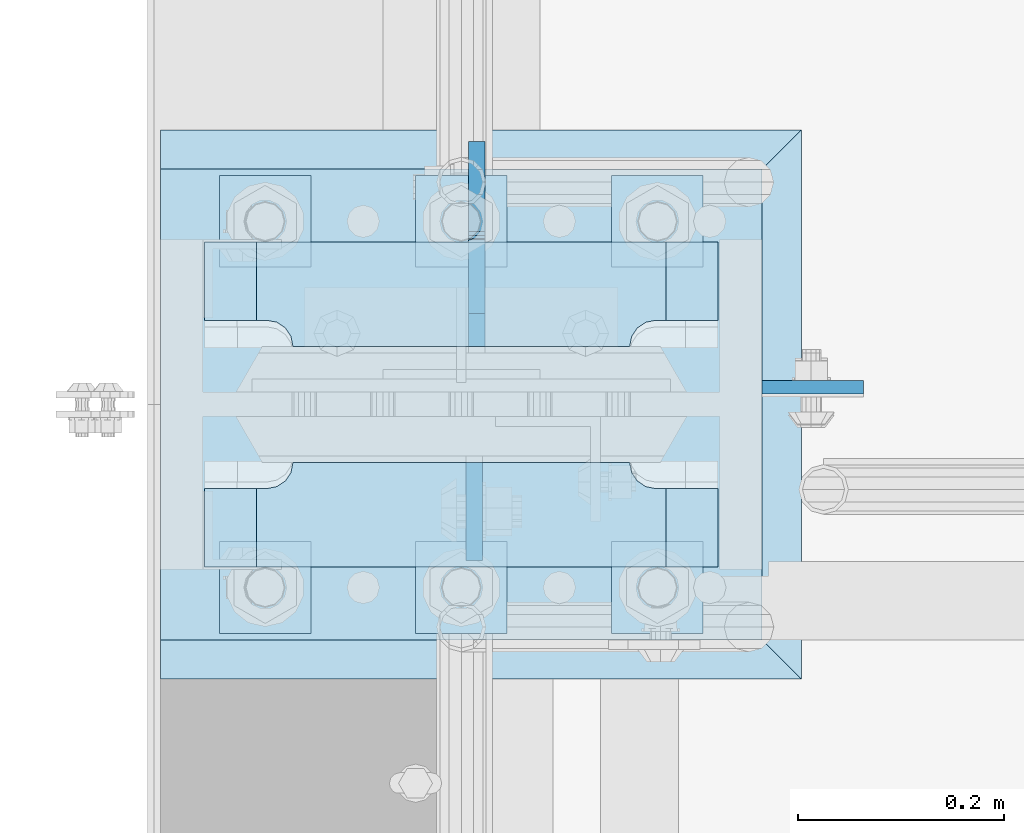
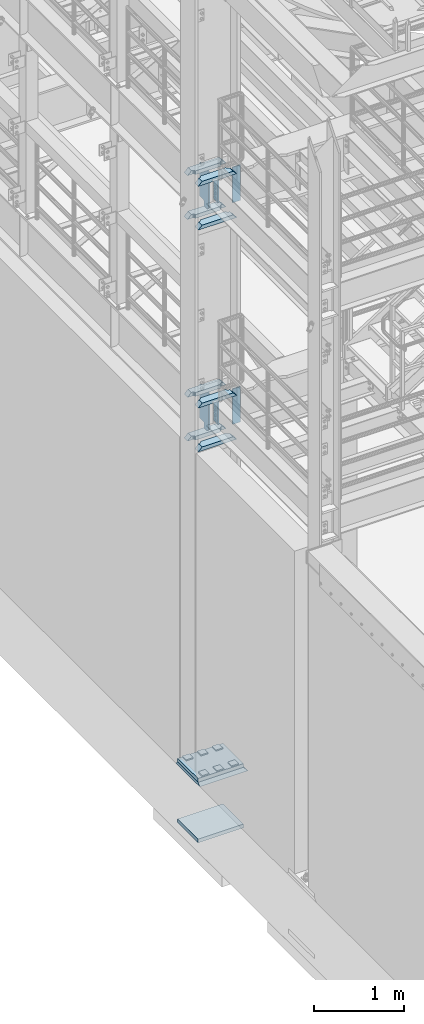
# One storey, part 1465 of 1876: 23 plates, 3 elements without a shape of their own.
"""IFC2X3 building model written with IfcOpenShell, lengths in millimetres."""

from ifc_helpers import new_model, si_unit, frame, origin_with_axes, place, context, subcontext, project, spatial, faceted_brep, material, type_object, element, aggregate, save


model = new_model("IFC2X3")

# Units and contexts
model_context = context("Model", 3, precision=1e-05, world=origin_with_axes())
body_context = subcontext(model_context, "Body", "Model", "MODEL_VIEW")
ifc_project = project(units=[si_unit("LENGTHUNIT", "METRE", prefix="MILLI"), si_unit("AREAUNIT", "SQUARE_METRE"), si_unit("VOLUMEUNIT", "CUBIC_METRE"), si_unit("MASSUNIT", "GRAM", prefix="KILO"), si_unit("TIMEUNIT", "SECOND"), si_unit("PLANEANGLEUNIT", "RADIAN"), si_unit("SOLIDANGLEUNIT", "STERADIAN"), si_unit("THERMODYNAMICTEMPERATUREUNIT", "DEGREE_CELSIUS"), si_unit("LUMINOUSINTENSITYUNIT", "LUMEN")], contexts=[model_context])

# Site, building, storey
site_placement = place(None, origin_with_axes())
site = spatial("IfcSite", under=ifc_project, at=site_placement, CompositionType="ELEMENT")
building_placement = place(site_placement, origin_with_axes())
building = spatial("IfcBuilding", under=site, at=building_placement, Name="Undefined", CompositionType="ELEMENT")
storey_placement = place(building_placement, origin_with_axes())
storey = spatial("IfcBuildingStorey", under=building, at=storey_placement, Name="Undefined", CompositionType="ELEMENT", Elevation=0.0)

# Assembly, plate
assembly_1_placement = place(storey_placement, origin_with_axes())
assembly_1 = element("IfcElementAssembly", 1, at=assembly_1_placement, inside=storey, Name="GROUT", AssemblyPlace="NOTDEFINED", PredefinedType="REINFORCEMENT_UNIT")
ifc_material_1 = material(Name="CONCRETE/Concrete_Undefined")
plate_type_1 = type_object("IfcPlateType", PredefinedType="NOTDEFINED")
plate_1_placement = place(assembly_1_placement, frame((-330.2, -4838.7, 19.05), z_axis=(0.0, 1.0, 0.0), x_axis=(1.0, 0.0, 0.0)))
plate_1 = element("IfcPlate", 2, at=plate_1_placement, type_object=plate_type_1, material=ifc_material_1, Name="GROUT", context=body_context, shape_type="Brep", body=[
    faceted_brep([(38.1, 19.0499984741211, 533.400024414062), (38.1, 19.05, 0.0), (38.1000000120275, -19.05, 38.1000000109725), (38.100000011611, -19.05, 495.299999988873), (622.299999999984, -19.05, 38.1000000000167), (660.400024414062, 19.05, 0.0), (660.400024414062, 19.05, 533.400024414062), (622.299999999999, -19.05, 495.299999999985)], [[[0, 1, 2, 3]], [[4, 5, 6, 7]], [[7, 6, 0, 3]], [[4, 7, 3, 2]], [[5, 4, 2, 1]], [[6, 5, 1, 0]]]),
])
aggregate(assembly_1, [plate_1])

# Assembly, plates
assembly_2_placement = place(storey_placement, origin_with_axes())
assembly_2 = element("IfcElementAssembly", 3, at=assembly_2_placement, inside=storey, Name="COLUMN", AssemblyPlace="NOTDEFINED", PredefinedType="RIGID_FRAME")
ifc_material_2 = material(Name="STEEL/A572-50")
plate_type_2 = type_object("IfcPlateType", PredefinedType="NOTDEFINED")
plate_2_placement = place(assembly_2_placement, frame((292.1, -4555.33200016022, 8070.85), z_axis=(1.0, 0.0, 0.0), x_axis=(0.0, 0.0, -1.0)))
plate_2 = element("IfcPlate", 4, at=plate_2_placement, type_object=plate_type_2, material=ifc_material_2, Name="PLATE", context=body_context, shape_type="Brep", body=[
    faceted_brep([(0.0, -6.35000000000036, 0.0), (0.0, -6.34999999999991, 98.4250030517578), (0.0, 6.34999999999991, 98.4250030517578), (0.0, 6.35000000000036, 0.0), (482.600006103516, -6.35000000000036, 98.4250030517578), (482.600006103516, 6.35000000000036, 98.4250030517578), (482.600006103516, -6.35000000000036, 0.0), (482.600006103516, 6.35000000000036, 0.0)], [[[0, 1, 2, 3]], [[1, 4, 5, 2]], [[4, 6, 7, 5]], [[6, 0, 3, 7]], [[5, 7, 3, 2]], [[6, 4, 1, 0]]]),
])
plate_3_placement = place(assembly_2_placement, frame((292.1, -4555.33200016022, 5048.25), z_axis=(1.0, 0.0, 0.0), x_axis=(0.0, 0.0, -1.0)))
plate_3 = element("IfcPlate", 5, at=plate_3_placement, type_object=plate_type_2, material=ifc_material_2, Name="PLATE", context=body_context, shape_type="Brep", body=[
    faceted_brep([(0.0, -6.35000000000036, 0.0), (0.0, -6.34999999999991, 98.4250030517578), (0.0, 6.34999999999991, 98.4250030517578), (0.0, 6.35000000000036, 0.0), (482.600006103516, -6.35000000000036, 98.4250030517578), (482.600006103516, 6.35000000000036, 98.4250030517578), (482.600006103516, -6.35000000000036, 0.0), (482.600006103516, 6.35000000000036, 0.0)], [[[0, 1, 2, 3]], [[1, 4, 5, 2]], [[4, 6, 7, 5]], [[6, 0, 3, 7]], [[5, 7, 3, 2]], [[6, 4, 1, 0]]]),
])
plate_type_3 = type_object("IfcPlateType", PredefinedType="NOTDEFINED")
plate_4_placement = place(assembly_2_placement, frame((249.2375, -4628.35625, 7531.10002441406), z_axis=(-1.0, 0.0, 0.0), x_axis=(0.0, -1.0, 0.0)))
plate_4 = element("IfcPlate", 6, at=plate_4_placement, type_object=plate_type_3, material=ifc_material_2, Name="PLATE", context=body_context, shape_type="Brep", body=[
    faceted_brep([(101.599998474121, -25.3999999999996, 498.475006103516), (101.599998474121, 25.3999999999996, 447.975004579813), (25.3999996185303, 25.3999999999996, 447.975004579813), (25.3999996185303, -25.3999999999996, 498.475006103516), (23.4665397733534, -25.3999999999996, 428.429848211837), (25.3999996185303, -25.3999999999996, 438.150007247925), (25.3999996185303, 25.3999999999996, 438.150007247925), (23.4665397733534, 25.3999999999996, 428.429848211837), (17.9605119723965, -25.3999999999996, 420.189495275529), (17.9605119723965, 25.3999999999996, 420.189495275529), (9.72015903608917, -25.3999999999996, 414.683467474573), (9.72015903608917, 25.3999999999996, 414.683467474573), (0.0, -25.3999999999996, 412.750007629395), (0.0, 25.3999999999996, 412.750007629395), (0.0, -25.3999999999996, 85.7249984741211), (0.0, 25.3999999999996, 85.7249984741211), (9.72015903609099, -25.3999999999996, 83.7915386289451), (9.72015903609099, 25.3999999999996, 83.7915386289451), (17.9605119723983, -25.3999999999996, 78.2855108279891), (17.9605119723983, 25.3999999999996, 78.2855108279891), (23.4665397733552, -25.3999999999996, 70.0451578916818), (23.4665397733552, 25.3999999999996, 70.0451578916818), (25.3999996185303, -25.3999999999996, 60.3249988555908), (25.3999996185303, 25.3999999999996, 60.3249988555908), (25.3999996185303, 25.3999999999996, 50.5000015237028), (25.3999996185303, -25.3999999999996, 0.0), (101.599998474121, 25.3999999999996, 50.5000015237028), (101.599998474121, -25.3999999999996, 0.0)], [[[0, 1, 2, 3]], [[4, 5, 6, 7]], [[8, 4, 7, 9]], [[10, 8, 9, 11]], [[12, 10, 11, 13]], [[14, 12, 13, 15]], [[16, 14, 15, 17]], [[18, 16, 17, 19]], [[20, 18, 19, 21]], [[22, 20, 21, 23]], [[22, 23, 24, 25]], [[26, 27, 25, 24]], [[5, 4, 8, 10, 12, 14, 16, 18, 20, 22, 25, 27, 0, 3]], [[6, 5, 3, 2]], [[26, 24, 23, 21, 19, 17, 15, 13, 11, 9, 7, 6, 2, 1]], [[27, 26, 1, 0]]]),
])
plate_5_placement = place(assembly_2_placement, frame((249.2375, -4628.35625, 8128.0), z_axis=(-1.0, 0.0, 0.0), x_axis=(0.0, -1.0, 0.0)))
plate_5 = element("IfcPlate", 7, at=plate_5_placement, type_object=plate_type_3, material=ifc_material_2, Name="PLATE", context=body_context, shape_type="Brep", body=[
    faceted_brep([(101.599998474121, -25.3999999999996, 498.475006103516), (101.599998474121, 25.3999999999996, 447.975004579813), (25.3999996185303, 25.3999999999996, 447.975004579813), (25.3999996185303, -25.3999999999996, 498.475006103516), (23.4665397733534, -25.3999999999996, 428.429848211837), (25.3999996185303, -25.3999999999996, 438.150007247925), (25.3999996185303, 25.3999999999996, 438.150007247925), (23.4665397733534, 25.3999999999996, 428.429848211837), (17.9605119723965, -25.3999999999996, 420.189495275529), (17.9605119723965, 25.3999999999996, 420.189495275529), (9.72015903608917, -25.3999999999996, 414.683467474573), (9.72015903608917, 25.3999999999996, 414.683467474573), (0.0, -25.3999999999996, 412.750007629395), (0.0, 25.3999999999996, 412.750007629395), (0.0, -25.3999999999996, 85.7249984741211), (0.0, 25.3999999999996, 85.7249984741211), (9.72015903609099, -25.3999999999996, 83.7915386289451), (9.72015903609099, 25.3999999999996, 83.7915386289451), (17.9605119723983, -25.3999999999996, 78.2855108279891), (17.9605119723983, 25.3999999999996, 78.2855108279891), (23.4665397733552, -25.3999999999996, 70.0451578916818), (23.4665397733552, 25.3999999999996, 70.0451578916818), (25.3999996185303, -25.3999999999996, 60.3249988555908), (25.3999996185303, 25.3999999999996, 60.3249988555908), (25.3999996185303, 25.3999999999996, 50.5000015237028), (25.3999996185303, -25.3999999999996, 0.0), (101.599998474121, 25.3999999999996, 50.5000015237028), (101.599998474121, -25.3999999999996, 0.0)], [[[0, 1, 2, 3]], [[4, 5, 6, 7]], [[8, 4, 7, 9]], [[10, 8, 9, 11]], [[12, 10, 11, 13]], [[14, 12, 13, 15]], [[16, 14, 15, 17]], [[18, 16, 17, 19]], [[20, 18, 19, 21]], [[22, 20, 21, 23]], [[22, 23, 24, 25]], [[26, 27, 25, 24]], [[5, 4, 8, 10, 12, 14, 16, 18, 20, 22, 25, 27, 0, 3]], [[6, 5, 3, 2]], [[26, 24, 23, 21, 19, 17, 15, 13, 11, 9, 7, 6, 2, 1]], [[27, 26, 1, 0]]]),
])
plate_6_placement = place(assembly_2_placement, frame((249.2375, -4414.04375, 7531.10002441406), z_axis=(-1.0, 0.0, 0.0), x_axis=(0.0, -1.0, 0.0)))
plate_6 = element("IfcPlate", 8, at=plate_6_placement, type_object=plate_type_3, material=ifc_material_2, Name="PLATE", context=body_context, shape_type="Brep", body=[
    faceted_brep([(76.1999988555908, -25.3999999999996, 498.475006103516), (76.1999988555908, 25.3999999999996, 447.975004579812), (0.0, 25.3999999999996, 447.975004579812), (0.0, -25.3999999999996, 498.475006103516), (76.1999988555908, 25.3999999999996, 50.5000015237032), (76.1999988555908, -25.3999999999996, 0.0), (0.0, -25.3999996185375, 0.0), (0.0, 25.3999999999996, 50.5000015237032), (76.1999988555908, 25.3999999999996, 60.3249988555908), (76.1999988555908, -25.3999999999996, 60.3249988555908), (78.1334587007668, -25.3999999999996, 70.045157891682), (78.1334587007668, 25.3999999999996, 70.045157891682), (83.6394865017228, -25.3999999999996, 78.2855108279893), (83.6394865017228, 25.3999999999996, 78.2855108279893), (91.8798394380301, -25.3999999999996, 83.7915386289454), (91.8798394380301, 25.3999999999996, 83.7915386289454), (101.599998474121, -25.3999999999996, 85.7249984741211), (101.599998474121, 25.3999999999996, 85.7249984741211), (101.599998474121, -25.3999999999996, 412.750007629395), (101.599998474121, 25.3999999999996, 412.750007629395), (91.8798394380301, -25.3999999999996, 414.68346747457), (91.8798394380301, 25.3999999999996, 414.68346747457), (83.6394865017219, -25.3999999999996, 420.189495275526), (83.6394865017219, 25.3999999999996, 420.189495275526), (78.1334587007659, -25.3999999999996, 428.429848211834), (78.1334587007659, 25.3999999999996, 428.429848211834), (76.1999988555908, -25.3999999999996, 438.150007247925), (76.1999988555908, 25.3999999999996, 438.150007247925)], [[[0, 1, 2, 3]], [[4, 5, 6, 7]], [[8, 9, 5, 4]], [[10, 9, 8, 11]], [[12, 10, 11, 13]], [[14, 12, 13, 15]], [[16, 14, 15, 17]], [[18, 16, 17, 19]], [[20, 18, 19, 21]], [[22, 20, 21, 23]], [[24, 22, 23, 25]], [[26, 24, 25, 27]], [[6, 5, 9, 10, 12, 14, 16, 18, 20, 22, 24, 26, 0, 3]], [[7, 6, 3, 2]], [[27, 25, 23, 21, 19, 17, 15, 13, 11, 8, 4, 7, 2, 1]], [[26, 27, 1, 0]]]),
])
plate_7_placement = place(assembly_2_placement, frame((249.2375, -4414.04375, 8128.0), z_axis=(-1.0, 0.0, 0.0), x_axis=(0.0, -1.0, 0.0)))
plate_7 = element("IfcPlate", 9, at=plate_7_placement, type_object=plate_type_3, material=ifc_material_2, Name="PLATE", context=body_context, shape_type="Brep", body=[
    faceted_brep([(76.1999988555908, -25.3999999999996, 498.475006103516), (76.1999988555908, 25.3999999999996, 447.975004579812), (0.0, 25.3999999999996, 447.975004579812), (0.0, -25.3999999999996, 498.475006103516), (76.1999988555908, 25.3999999999996, 50.5000015237032), (76.1999988555908, -25.3999999999996, 0.0), (0.0, -25.3999996185375, 0.0), (0.0, 25.3999999999996, 50.5000015237032), (76.1999988555908, 25.3999999999996, 60.3249988555908), (76.1999988555908, -25.3999999999996, 60.3249988555908), (78.1334587007668, -25.3999999999996, 70.045157891682), (78.1334587007668, 25.3999999999996, 70.045157891682), (83.6394865017228, -25.3999999999996, 78.2855108279893), (83.6394865017228, 25.3999999999996, 78.2855108279893), (91.8798394380301, -25.3999999999996, 83.7915386289454), (91.8798394380301, 25.3999999999996, 83.7915386289454), (101.599998474121, -25.3999999999996, 85.7249984741211), (101.599998474121, 25.3999999999996, 85.7249984741211), (101.599998474121, -25.3999999999996, 412.750007629395), (101.599998474121, 25.3999999999996, 412.750007629395), (91.8798394380301, -25.3999999999996, 414.68346747457), (91.8798394380301, 25.3999999999996, 414.68346747457), (83.6394865017219, -25.3999999999996, 420.189495275526), (83.6394865017219, 25.3999999999996, 420.189495275526), (78.1334587007659, -25.3999999999996, 428.429848211834), (78.1334587007659, 25.3999999999996, 428.429848211834), (76.1999988555908, -25.3999999999996, 438.150007247925), (76.1999988555908, 25.3999999999996, 438.150007247925)], [[[0, 1, 2, 3]], [[4, 5, 6, 7]], [[8, 9, 5, 4]], [[10, 9, 8, 11]], [[12, 10, 11, 13]], [[14, 12, 13, 15]], [[16, 14, 15, 17]], [[18, 16, 17, 19]], [[20, 18, 19, 21]], [[22, 20, 21, 23]], [[24, 22, 23, 25]], [[26, 24, 25, 27]], [[6, 5, 9, 10, 12, 14, 16, 18, 20, 22, 24, 26, 0, 3]], [[7, 6, 3, 2]], [[27, 25, 23, 21, 19, 17, 15, 13, 11, 8, 4, 7, 2, 1]], [[26, 27, 1, 0]]]),
])
plate_8_placement = place(assembly_2_placement, frame((249.2375, -4628.35625, 4508.50002441406), z_axis=(-1.0, 0.0, 0.0), x_axis=(0.0, -1.0, 0.0)))
plate_8 = element("IfcPlate", 10, at=plate_8_placement, type_object=plate_type_3, material=ifc_material_2, Name="PLATE", context=body_context, shape_type="Brep", body=[
    faceted_brep([(101.599998474121, -25.3999999999996, 498.475006103516), (101.599998474121, 25.3999999999996, 447.975004579813), (25.3999996185303, 25.3999999999996, 447.975004579813), (25.3999996185303, -25.3999999999996, 498.475006103516), (23.4665397733534, -25.3999999999996, 428.429848211837), (25.3999996185303, -25.3999999999996, 438.150007247925), (25.3999996185303, 25.3999999999996, 438.150007247925), (23.4665397733534, 25.3999999999996, 428.429848211837), (17.9605119723965, -25.3999999999996, 420.189495275529), (17.9605119723965, 25.3999999999996, 420.189495275529), (9.72015903608917, -25.3999999999996, 414.683467474573), (9.72015903608917, 25.3999999999996, 414.683467474573), (0.0, -25.3999999999996, 412.750007629395), (0.0, 25.3999999999996, 412.750007629395), (0.0, -25.3999999999996, 85.7249984741211), (0.0, 25.3999999999996, 85.7249984741211), (9.72015903609099, -25.3999999999996, 83.7915386289451), (9.72015903609099, 25.3999999999996, 83.7915386289451), (17.9605119723983, -25.3999999999996, 78.2855108279891), (17.9605119723983, 25.3999999999996, 78.2855108279891), (23.4665397733552, -25.3999999999996, 70.0451578916818), (23.4665397733552, 25.3999999999996, 70.0451578916818), (25.3999996185303, -25.3999999999996, 60.3249988555908), (25.3999996185303, 25.3999999999996, 60.3249988555908), (25.3999996185303, 25.3999999999996, 50.5000015237028), (25.3999996185303, -25.3999999999996, 0.0), (101.599998474121, 25.3999999999996, 50.5000015237028), (101.599998474121, -25.3999999999996, 0.0)], [[[0, 1, 2, 3]], [[4, 5, 6, 7]], [[8, 4, 7, 9]], [[10, 8, 9, 11]], [[12, 10, 11, 13]], [[14, 12, 13, 15]], [[16, 14, 15, 17]], [[18, 16, 17, 19]], [[20, 18, 19, 21]], [[22, 20, 21, 23]], [[22, 23, 24, 25]], [[26, 27, 25, 24]], [[5, 4, 8, 10, 12, 14, 16, 18, 20, 22, 25, 27, 0, 3]], [[6, 5, 3, 2]], [[26, 24, 23, 21, 19, 17, 15, 13, 11, 9, 7, 6, 2, 1]], [[27, 26, 1, 0]]]),
])
plate_9_placement = place(assembly_2_placement, frame((249.2375, -4628.35625, 5105.4), z_axis=(-1.0, 0.0, 0.0), x_axis=(0.0, -1.0, 0.0)))
plate_9 = element("IfcPlate", 11, at=plate_9_placement, type_object=plate_type_3, material=ifc_material_2, Name="PLATE", context=body_context, shape_type="Brep", body=[
    faceted_brep([(101.599998474121, -25.3999999999996, 498.475006103516), (101.599998474121, 25.3999999999996, 447.975004579813), (25.3999996185303, 25.3999999999996, 447.975004579813), (25.3999996185303, -25.3999999999996, 498.475006103516), (23.4665397733534, -25.3999999999996, 428.429848211837), (25.3999996185303, -25.3999999999996, 438.150007247925), (25.3999996185303, 25.3999999999996, 438.150007247925), (23.4665397733534, 25.3999999999996, 428.429848211837), (17.9605119723965, -25.3999999999996, 420.189495275529), (17.9605119723965, 25.3999999999996, 420.189495275529), (9.72015903608917, -25.3999999999996, 414.683467474573), (9.72015903608917, 25.3999999999996, 414.683467474573), (0.0, -25.3999999999996, 412.750007629395), (0.0, 25.3999999999996, 412.750007629395), (0.0, -25.3999999999996, 85.7249984741211), (0.0, 25.3999999999996, 85.7249984741211), (9.72015903609099, -25.3999999999996, 83.7915386289451), (9.72015903609099, 25.3999999999996, 83.7915386289451), (17.9605119723983, -25.3999999999996, 78.2855108279891), (17.9605119723983, 25.3999999999996, 78.2855108279891), (23.4665397733552, -25.3999999999996, 70.0451578916818), (23.4665397733552, 25.3999999999996, 70.0451578916818), (25.3999996185303, -25.3999999999996, 60.3249988555908), (25.3999996185303, 25.3999999999996, 60.3249988555908), (25.3999996185303, 25.3999999999996, 50.5000015237028), (25.3999996185303, -25.3999999999996, 0.0), (101.599998474121, 25.3999999999996, 50.5000015237028), (101.599998474121, -25.3999999999996, 0.0)], [[[0, 1, 2, 3]], [[4, 5, 6, 7]], [[8, 4, 7, 9]], [[10, 8, 9, 11]], [[12, 10, 11, 13]], [[14, 12, 13, 15]], [[16, 14, 15, 17]], [[18, 16, 17, 19]], [[20, 18, 19, 21]], [[22, 20, 21, 23]], [[22, 23, 24, 25]], [[26, 27, 25, 24]], [[5, 4, 8, 10, 12, 14, 16, 18, 20, 22, 25, 27, 0, 3]], [[6, 5, 3, 2]], [[26, 24, 23, 21, 19, 17, 15, 13, 11, 9, 7, 6, 2, 1]], [[27, 26, 1, 0]]]),
])
plate_10_placement = place(assembly_2_placement, frame((249.2375, -4414.04375, 4508.50002441406), z_axis=(-1.0, 0.0, 0.0), x_axis=(0.0, -1.0, 0.0)))
plate_10 = element("IfcPlate", 12, at=plate_10_placement, type_object=plate_type_3, material=ifc_material_2, Name="PLATE", context=body_context, shape_type="Brep", body=[
    faceted_brep([(76.1999988555908, -25.3999999999996, 498.475006103516), (76.1999988555908, 25.3999999999996, 447.975004579812), (0.0, 25.3999999999996, 447.975004579812), (0.0, -25.3999999999996, 498.475006103516), (76.1999988555908, 25.3999999999996, 50.5000015237032), (76.1999988555908, -25.3999999999996, 0.0), (0.0, -25.3999996185375, 0.0), (0.0, 25.3999999999996, 50.5000015237032), (76.1999988555908, 25.3999999999996, 60.3249988555908), (76.1999988555908, -25.3999999999996, 60.3249988555908), (78.1334587007668, -25.3999999999996, 70.045157891682), (78.1334587007668, 25.3999999999996, 70.045157891682), (83.6394865017228, -25.3999999999996, 78.2855108279893), (83.6394865017228, 25.3999999999996, 78.2855108279893), (91.8798394380301, -25.3999999999996, 83.7915386289454), (91.8798394380301, 25.3999999999996, 83.7915386289454), (101.599998474121, -25.3999999999996, 85.7249984741211), (101.599998474121, 25.3999999999996, 85.7249984741211), (101.599998474121, -25.3999999999996, 412.750007629395), (101.599998474121, 25.3999999999996, 412.750007629395), (91.8798394380301, -25.3999999999996, 414.68346747457), (91.8798394380301, 25.3999999999996, 414.68346747457), (83.6394865017219, -25.3999999999996, 420.189495275526), (83.6394865017219, 25.3999999999996, 420.189495275526), (78.1334587007659, -25.3999999999996, 428.429848211834), (78.1334587007659, 25.3999999999996, 428.429848211834), (76.1999988555908, -25.3999999999996, 438.150007247925), (76.1999988555908, 25.3999999999996, 438.150007247925)], [[[0, 1, 2, 3]], [[4, 5, 6, 7]], [[8, 9, 5, 4]], [[10, 9, 8, 11]], [[12, 10, 11, 13]], [[14, 12, 13, 15]], [[16, 14, 15, 17]], [[18, 16, 17, 19]], [[20, 18, 19, 21]], [[22, 20, 21, 23]], [[24, 22, 23, 25]], [[26, 24, 25, 27]], [[6, 5, 9, 10, 12, 14, 16, 18, 20, 22, 24, 26, 0, 3]], [[7, 6, 3, 2]], [[27, 25, 23, 21, 19, 17, 15, 13, 11, 8, 4, 7, 2, 1]], [[26, 27, 1, 0]]]),
])
plate_11_placement = place(assembly_2_placement, frame((249.2375, -4414.04375, 5105.4), z_axis=(-1.0, 0.0, 0.0), x_axis=(0.0, -1.0, 0.0)))
plate_11 = element("IfcPlate", 13, at=plate_11_placement, type_object=plate_type_3, material=ifc_material_2, Name="PLATE", context=body_context, shape_type="Brep", body=[
    faceted_brep([(76.1999988555908, -25.3999999999996, 498.475006103516), (76.1999988555908, 25.3999999999996, 447.975004579812), (0.0, 25.3999999999996, 447.975004579812), (0.0, -25.3999999999996, 498.475006103516), (76.1999988555908, 25.3999999999996, 50.5000015237032), (76.1999988555908, -25.3999999999996, 0.0), (0.0, -25.3999996185375, 0.0), (0.0, 25.3999999999996, 50.5000015237032), (76.1999988555908, 25.3999999999996, 60.3249988555908), (76.1999988555908, -25.3999999999996, 60.3249988555908), (78.1334587007668, -25.3999999999996, 70.045157891682), (78.1334587007668, 25.3999999999996, 70.045157891682), (83.6394865017228, -25.3999999999996, 78.2855108279893), (83.6394865017228, 25.3999999999996, 78.2855108279893), (91.8798394380301, -25.3999999999996, 83.7915386289454), (91.8798394380301, 25.3999999999996, 83.7915386289454), (101.599998474121, -25.3999999999996, 85.7249984741211), (101.599998474121, 25.3999999999996, 85.7249984741211), (101.599998474121, -25.3999999999996, 412.750007629395), (101.599998474121, 25.3999999999996, 412.750007629395), (91.8798394380301, -25.3999999999996, 414.68346747457), (91.8798394380301, 25.3999999999996, 414.68346747457), (83.6394865017219, -25.3999999999996, 420.189495275526), (83.6394865017219, 25.3999999999996, 420.189495275526), (78.1334587007659, -25.3999999999996, 428.429848211834), (78.1334587007659, 25.3999999999996, 428.429848211834), (76.1999988555908, -25.3999999999996, 438.150007247925), (76.1999988555908, 25.3999999999996, 438.150007247925)], [[[0, 1, 2, 3]], [[4, 5, 6, 7]], [[8, 9, 5, 4]], [[10, 9, 8, 11]], [[12, 10, 11, 13]], [[14, 12, 13, 15]], [[16, 14, 15, 17]], [[18, 16, 17, 19]], [[20, 18, 19, 21]], [[22, 20, 21, 23]], [[24, 22, 23, 25]], [[26, 24, 25, 27]], [[6, 5, 9, 10, 12, 14, 16, 18, 20, 22, 24, 26, 0, 3]], [[7, 6, 3, 2]], [[27, 25, 23, 21, 19, 17, 15, 13, 11, 8, 4, 7, 2, 1]], [[26, 27, 1, 0]]]),
])
ifc_material_3 = material(Name="STEEL/A36")
plate_type_4 = type_object("IfcPlateType", PredefinedType="NOTDEFINED")
plate_12_placement = place(assembly_2_placement, frame((12.6995000839233, -4628.35625, 8089.9), z_axis=(0.0, -1.0, 0.0), x_axis=(0.0, 0.0, -1.0)))
plate_12 = element("IfcPlate", 14, at=plate_12_placement, type_object=plate_type_4, material=ifc_material_3, Name="PLATE", context=body_context, shape_type="Brep", body=[
    faceted_brep([(0.0, -7.9375, 0.0), (0.0, -7.9375, 95.25), (0.0, 7.9375, 95.25), (0.0, 7.9375, 0.0), (304.799987792969, -7.9375, 95.25), (304.799987792969, 7.9375, 95.25), (304.799987792969, -7.9375, 0.0), (304.799987792969, 7.9375, 0.0)], [[[0, 1, 2, 3]], [[1, 4, 5, 2]], [[4, 6, 7, 5]], [[6, 0, 3, 7]], [[5, 7, 3, 2]], [[6, 4, 1, 0]]]),
])
plate_13_placement = place(assembly_2_placement, frame((12.6995000839233, -4628.35625, 5067.3), z_axis=(0.0, -1.0, 0.0), x_axis=(0.0, 0.0, -1.0)))
plate_13 = element("IfcPlate", 15, at=plate_13_placement, type_object=plate_type_4, material=ifc_material_3, Name="PLATE", context=body_context, shape_type="Brep", body=[
    faceted_brep([(0.0, -7.9375, 0.0), (0.0, -7.9375, 95.25), (0.0, 7.9375, 95.25), (0.0, 7.9375, 0.0), (304.799987792969, -7.9375, 95.25), (304.799987792969, 7.9375, 95.25), (304.799987792969, -7.9375, 0.0), (304.799987792969, 7.9375, 0.0)], [[[0, 1, 2, 3]], [[1, 4, 5, 2]], [[4, 6, 7, 5]], [[6, 0, 3, 7]], [[5, 7, 3, 2]], [[6, 4, 1, 0]]]),
])
plate_type_5 = type_object("IfcPlateType", PredefinedType="NOTDEFINED")
plate_14_placement = place(assembly_2_placement, frame((15.080500125885, -4515.64375, 8102.6), z_axis=(0.0, 1.0, 0.0), x_axis=(0.0, 0.0, -1.0)))
plate_14 = element("IfcPlate", 16, at=plate_14_placement, type_object=plate_type_5, material=ifc_material_3, Name="PLATE", context=body_context, shape_type="Brep", body=[
    faceted_brep([(469.900012207031, -7.9375, 199.231247384208), (469.900012207031, -7.9375, 116.681246757507), (469.900012207031, 7.9375, 116.681246757507), (469.900012207031, 7.9375, 199.231246948242), (470.866742129619, -7.9375, 111.821167239462), (470.866742129619, 7.9375, 111.821167239462), (473.619756030097, -7.9375, 107.700990771308), (473.619756030097, 7.9375, 107.700990771308), (477.739932498251, -7.9375, 104.94797687083), (477.739932498251, 7.9375, 104.94797687083), (482.600012016296, -7.9375, 103.981246948242), (482.600012016296, 7.9375, 103.981246948242), (546.099975585938, -7.9375, 103.981246948242), (546.099975585938, 7.9375, 103.981246948242), (12.6999996185305, -7.9375, 199.231249999999), (12.6999996185305, 7.9375, 199.231246948242), (12.6999996185305, 7.9375, 116.681249809264), (12.6999996185305, -7.9375, 116.681249809264), (11.7332696959429, 7.9375, 111.821170291219), (11.7332696959429, -7.9375, 111.821170291219), (8.98025579546447, 7.9375, 107.700993823065), (8.98025579546447, -7.9375, 107.700993823065), (4.86007932731081, 7.9375, 104.947979922586), (4.86007932731081, -7.9375, 104.947979922586), (0.0, 7.9375, 103.981249999999), (0.0, -7.9375, 103.981249999999), (0.0, 7.93749999999999, 31.75), (0.0, -7.93749999999998, 31.75), (31.75, -7.93749999999998, 0.0), (31.75, 7.93749999999999, 0.0), (514.349975585938, -7.9375, 0.0), (514.349975585938, 7.9375, 0.0), (546.099975585938, -7.9375, 31.75), (546.099975585938, 7.9375, 31.75)], [[[0, 1, 2, 3]], [[4, 5, 2, 1]], [[6, 7, 5, 4]], [[8, 9, 7, 6]], [[10, 11, 9, 8]], [[12, 13, 11, 10]], [[14, 15, 16, 17]], [[17, 16, 18, 19]], [[19, 18, 20, 21]], [[21, 20, 22, 23]], [[23, 22, 24, 25]], [[26, 27, 25, 24]], [[28, 27, 26, 29]], [[30, 28, 29, 31]], [[32, 30, 31, 33]], [[8, 6, 4, 1, 0, 14, 17, 19, 21, 23, 25, 27, 28, 30, 32, 12, 10]], [[15, 14, 0, 3]], [[33, 31, 29, 26, 24, 22, 20, 18, 16, 15, 3, 2, 5, 7, 9, 11, 13]], [[32, 33, 13, 12]]]),
])
plate_15_placement = place(assembly_2_placement, frame((15.0805001258851, -4515.64375, 5080.0), z_axis=(0.0, 1.0, 0.0), x_axis=(0.0, 0.0, -1.0)))
plate_15 = element("IfcPlate", 17, at=plate_15_placement, type_object=plate_type_5, material=ifc_material_3, Name="PLATE", context=body_context, shape_type="Brep", body=[
    faceted_brep([(469.900012207031, -7.9375, 199.231247384208), (469.900012207031, -7.9375, 116.681246757507), (469.900012207031, 7.9375, 116.681246757507), (469.900012207031, 7.9375, 199.231246948242), (470.866742129619, -7.9375, 111.821167239462), (470.866742129619, 7.9375, 111.821167239462), (473.619756030097, -7.9375, 107.700990771308), (473.619756030097, 7.9375, 107.700990771308), (477.739932498251, -7.9375, 104.94797687083), (477.739932498251, 7.9375, 104.94797687083), (482.600012016296, -7.9375, 103.981246948242), (482.600012016296, 7.9375, 103.981246948242), (546.099975585938, -7.9375, 103.981246948242), (546.099975585938, 7.9375, 103.981246948242), (12.6999996185305, -7.9375, 199.231249999999), (12.6999996185305, 7.9375, 199.231246948242), (12.6999996185305, 7.9375, 116.681249809264), (12.6999996185305, -7.9375, 116.681249809264), (11.7332696959429, 7.9375, 111.821170291219), (11.7332696959429, -7.9375, 111.821170291219), (8.98025579546447, 7.9375, 107.700993823065), (8.98025579546447, -7.9375, 107.700993823065), (4.86007932731081, 7.9375, 104.947979922586), (4.86007932731081, -7.9375, 104.947979922586), (0.0, 7.9375, 103.981249999999), (0.0, -7.9375, 103.981249999999), (0.0, 7.93749999999999, 31.75), (0.0, -7.93749999999998, 31.75), (31.75, -7.93749999999998, 0.0), (31.75, 7.93749999999999, 0.0), (514.349975585938, -7.9375, 0.0), (514.349975585938, 7.9375, 0.0), (546.099975585938, -7.9375, 31.75), (546.099975585938, 7.9375, 31.75)], [[[0, 1, 2, 3]], [[4, 5, 2, 1]], [[6, 7, 5, 4]], [[8, 9, 7, 6]], [[10, 11, 9, 8]], [[12, 13, 11, 10]], [[14, 15, 16, 17]], [[17, 16, 18, 19]], [[19, 18, 20, 21]], [[21, 20, 22, 23]], [[23, 22, 24, 25]], [[26, 27, 25, 24]], [[28, 27, 26, 29]], [[30, 28, 29, 31]], [[32, 30, 31, 33]], [[8, 6, 4, 1, 0, 14, 17, 19, 21, 23, 25, 27, 28, 30, 32, 12, 10]], [[15, 14, 0, 3]], [[33, 31, 29, 26, 24, 22, 20, 18, 16, 15, 3, 2, 5, 7, 9, 11, 13]], [[32, 33, 13, 12]]]),
])

assembly_3_placement = place(storey_placement, origin_with_axes())
assembly_3 = element("IfcElementAssembly", 18, at=assembly_3_placement, inside=storey, Name="TEMPLATE", AssemblyPlace="NOTDEFINED", PredefinedType="RIGID_FRAME")
plate_type_6 = type_object("IfcPlateType", PredefinedType="NOTDEFINED")
plate_16_placement = place(assembly_3_placement, frame((146.05, -4705.35, 96.8375), z_axis=(0.0, -1.0, 0.0), x_axis=(1.0, 0.0, 0.0)))
plate_16 = element("IfcPlate", 19, at=plate_16_placement, type_object=plate_type_6, material=ifc_material_2, Name="PLATE WASHER", context=body_context, shape_type="Brep", body=[
    faceted_brep([(0.0, -7.9375, 0.0), (0.0, -7.9375, 88.9000015258789), (0.0, 7.9375, 88.9000015258789), (0.0, 7.9375, 0.0), (88.9000015258789, -7.9375, 88.9000015258789), (88.9000015258789, 7.9375, 88.9000015258789), (88.9000015258789, -7.9375, 0.0), (88.9000015258789, 7.9375, 0.0)], [[[0, 1, 2, 3]], [[1, 4, 5, 2]], [[4, 6, 7, 5]], [[6, 0, 3, 7]], [[5, 7, 3, 2]], [[6, 4, 1, 0]]]),
])
plate_17_placement = place(assembly_3_placement, frame((146.05, -4349.75, 96.8375), z_axis=(0.0, -1.0, 0.0), x_axis=(1.0, 0.0, 0.0)))
plate_17 = element("IfcPlate", 20, at=plate_17_placement, type_object=plate_type_6, material=ifc_material_2, Name="PLATE WASHER", context=body_context, shape_type="Brep", body=[
    faceted_brep([(0.0, -7.9375, 0.0), (0.0, -7.9375, 88.9000015258789), (0.0, 7.9375, 88.9000015258789), (0.0, 7.9375, 0.0), (88.9000015258789, -7.9375, 88.9000015258789), (88.9000015258789, 7.9375, 88.9000015258789), (88.9000015258789, -7.9375, 0.0), (88.9000015258789, 7.9375, 0.0)], [[[0, 1, 2, 3]], [[1, 4, 5, 2]], [[4, 6, 7, 5]], [[6, 0, 3, 7]], [[5, 7, 3, 2]], [[6, 4, 1, 0]]]),
])
plate_18_placement = place(assembly_3_placement, frame((-44.45, -4705.35, 96.8375), z_axis=(0.0, -1.0, 0.0), x_axis=(1.0, 0.0, 0.0)))
plate_18 = element("IfcPlate", 21, at=plate_18_placement, type_object=plate_type_6, material=ifc_material_2, Name="PLATE WASHER", context=body_context, shape_type="Brep", body=[
    faceted_brep([(0.0, -7.9375, 0.0), (0.0, -7.9375, 88.9000015258789), (0.0, 7.9375, 88.9000015258789), (0.0, 7.9375, 0.0), (88.9000015258789, -7.9375, 88.9000015258789), (88.9000015258789, 7.9375, 88.9000015258789), (88.9000015258789, -7.9375, 0.0), (88.9000015258789, 7.9375, 0.0)], [[[0, 1, 2, 3]], [[1, 4, 5, 2]], [[4, 6, 7, 5]], [[6, 0, 3, 7]], [[5, 7, 3, 2]], [[6, 4, 1, 0]]]),
])
plate_19_placement = place(assembly_3_placement, frame((-44.45, -4349.75, 96.8375), z_axis=(0.0, -1.0, 0.0), x_axis=(1.0, 0.0, 0.0)))
plate_19 = element("IfcPlate", 22, at=plate_19_placement, type_object=plate_type_6, material=ifc_material_2, Name="PLATE WASHER", context=body_context, shape_type="Brep", body=[
    faceted_brep([(0.0, -7.9375, 0.0), (0.0, -7.9375, 88.9000015258789), (0.0, 7.9375, 88.9000015258789), (0.0, 7.9375, 0.0), (88.9000015258789, -7.9375, 88.9000015258789), (88.9000015258789, 7.9375, 88.9000015258789), (88.9000015258789, -7.9375, 0.0), (88.9000015258789, 7.9375, 0.0)], [[[0, 1, 2, 3]], [[1, 4, 5, 2]], [[4, 6, 7, 5]], [[6, 0, 3, 7]], [[5, 7, 3, 2]], [[6, 4, 1, 0]]]),
])
plate_20_placement = place(assembly_3_placement, frame((-234.95, -4705.35, 96.8375), z_axis=(0.0, -1.0, 0.0), x_axis=(1.0, 0.0, 0.0)))
plate_20 = element("IfcPlate", 23, at=plate_20_placement, type_object=plate_type_6, material=ifc_material_2, Name="PLATE WASHER", context=body_context, shape_type="Brep", body=[
    faceted_brep([(0.0, -7.9375, 0.0), (0.0, -7.9375, 88.9000015258789), (0.0, 7.9375, 88.9000015258789), (0.0, 7.9375, 0.0), (88.9000015258789, -7.9375, 88.9000015258789), (88.9000015258789, 7.9375, 88.9000015258789), (88.9000015258789, -7.9375, 0.0), (88.9000015258789, 7.9375, 0.0)], [[[0, 1, 2, 3]], [[1, 4, 5, 2]], [[4, 6, 7, 5]], [[6, 0, 3, 7]], [[5, 7, 3, 2]], [[6, 4, 1, 0]]]),
])
plate_21_placement = place(assembly_3_placement, frame((-234.95, -4349.75, 96.8375), z_axis=(0.0, -1.0, 0.0), x_axis=(1.0, 0.0, 0.0)))
plate_21 = element("IfcPlate", 24, at=plate_21_placement, type_object=plate_type_6, material=ifc_material_2, Name="PLATE WASHER", context=body_context, shape_type="Brep", body=[
    faceted_brep([(0.0, -7.9375, 0.0), (0.0, -7.9375, 88.9000015258789), (0.0, 7.9375, 88.9000015258789), (0.0, 7.9375, 0.0), (88.9000015258789, -7.9375, 88.9000015258789), (88.9000015258789, 7.9375, 88.9000015258789), (88.9000015258789, -7.9375, 0.0), (88.9000015258789, 7.9375, 0.0)], [[[0, 1, 2, 3]], [[1, 4, 5, 2]], [[4, 6, 7, 5]], [[6, 0, 3, 7]], [[5, 7, 3, 2]], [[6, 4, 1, 0]]]),
])
plate_type_7 = type_object("IfcPlateType", PredefinedType="NOTDEFINED")
plate_22_placement = place(assembly_3_placement, frame((-292.099999999999, -4800.6, -762.0), z_axis=(0.0, 1.0, 0.0), x_axis=(1.0, 0.0, 0.0)))
plate_22 = element("IfcPlate", 25, at=plate_22_placement, type_object=plate_type_7, material=ifc_material_2, Name="PLATE", context=body_context, shape_type="Brep", body=[
    faceted_brep([(0.0, -25.3999996185375, 0.0), (0.0, -25.4, 457.200012207031), (0.0, 25.4, 457.200012207031), (0.0, 25.3999996185339, 9.09494701772928e-13), (584.200012207031, -25.4, 457.200012207031), (584.200012207031, 25.4, 457.200012207031), (584.200012207031, -25.4, 0.0), (584.200012207031, 25.4, 0.0)], [[[0, 1, 2, 3]], [[1, 4, 5, 2]], [[4, 6, 7, 5]], [[6, 0, 3, 7]], [[5, 7, 3, 2]], [[6, 4, 1, 0]]]),
])
aggregate(assembly_3, [plate_22, plate_16, plate_17, plate_18, plate_19, plate_20, plate_21])

# Plate
ifc_material_4 = material(Name="STEEL/A572-GR.50")
plate_23_placement = place(assembly_2_placement, frame((-292.1, -4800.6, 63.5), z_axis=(0.0, 1.0, 0.0), x_axis=(1.0, 0.0, 0.0)))
plate_23 = element("IfcPlate", 26, at=plate_23_placement, type_object=plate_type_7, material=ifc_material_4, Name="PLATE", context=body_context, shape_type="Brep", body=[
    faceted_brep([(0.0, -25.3999996185375, 0.0), (0.0, -25.4, 457.200012207031), (0.0, 25.4, 457.200012207031), (0.0, 25.3999996185339, 9.09494701772928e-13), (584.200012207031, -25.4, 457.200012207031), (584.200012207031, 25.4, 457.200012207031), (584.200012207031, -25.4, 0.0), (584.200012207031, 25.4, 0.0)], [[[0, 1, 2, 3]], [[1, 4, 5, 2]], [[4, 6, 7, 5]], [[6, 0, 3, 7]], [[5, 7, 3, 2]], [[6, 4, 1, 0]]]),
])

aggregate(assembly_2, [plate_12, plate_4, plate_5, plate_6, plate_7, plate_14, plate_2, plate_13, plate_3, plate_8, plate_9, plate_10, plate_11, plate_15, plate_23])

save(model, "model.ifc")
